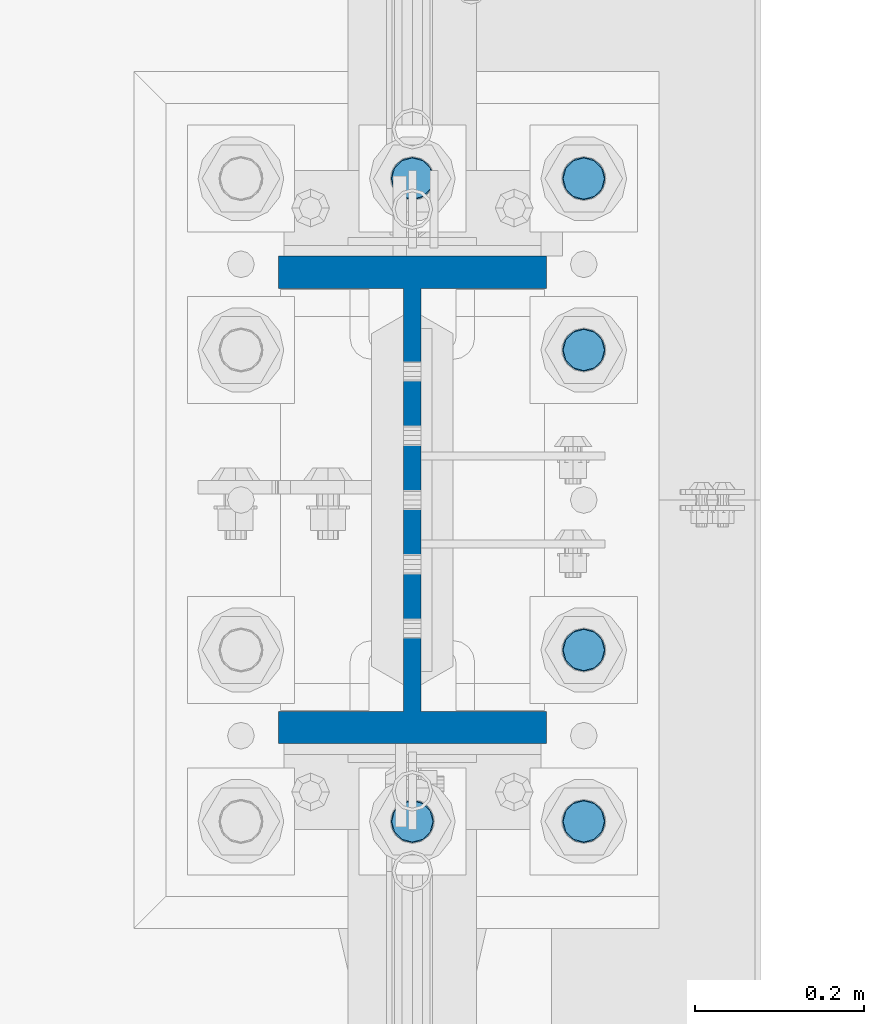
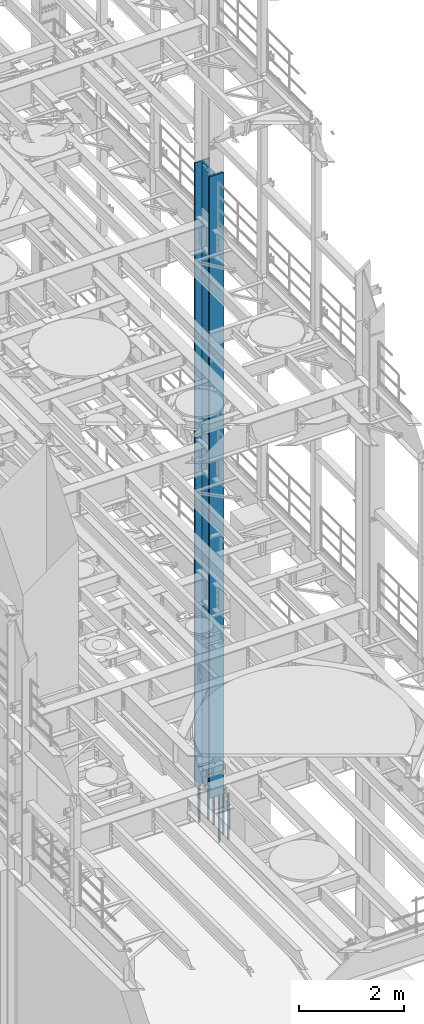
# One storey, part 758 of 1876: 7 columns, 2 elements without a shape of their own.
"""IFC2X3 building model written with IfcOpenShell, lengths in millimetres."""

from ifc_helpers import new_model, si_unit, frame, origin_with_axes, place, context, subcontext, project, spatial, faceted_brep, material, type_object, element, aggregate, save


model = new_model("IFC2X3")

# Units and contexts
model_context = context("Model", 3, precision=1e-05, world=origin_with_axes())
body_context = subcontext(model_context, "Body", "Model", "MODEL_VIEW")
ifc_project = project(units=[si_unit("LENGTHUNIT", "METRE", prefix="MILLI"), si_unit("AREAUNIT", "SQUARE_METRE"), si_unit("VOLUMEUNIT", "CUBIC_METRE"), si_unit("MASSUNIT", "GRAM", prefix="KILO"), si_unit("TIMEUNIT", "SECOND"), si_unit("PLANEANGLEUNIT", "RADIAN"), si_unit("SOLIDANGLEUNIT", "STERADIAN"), si_unit("THERMODYNAMICTEMPERATUREUNIT", "DEGREE_CELSIUS"), si_unit("LUMINOUSINTENSITYUNIT", "LUMEN")], contexts=[model_context])

# Site, building, storey
site_placement = place(None, origin_with_axes())
site = spatial("IfcSite", under=ifc_project, at=site_placement, CompositionType="ELEMENT")
building_placement = place(site_placement, origin_with_axes())
building = spatial("IfcBuilding", under=site, at=building_placement, Name="Undefined", CompositionType="ELEMENT")
storey_placement = place(building_placement, origin_with_axes())
storey = spatial("IfcBuildingStorey", under=building, at=storey_placement, Name="Undefined", CompositionType="ELEMENT", Elevation=0.0)

# Assembly, column
assembly_1_placement = place(storey_placement, origin_with_axes())
assembly_1 = element("IfcElementAssembly", 1, at=assembly_1_placement, inside=storey, Name="COLUMN", AssemblyPlace="NOTDEFINED", PredefinedType="RIGID_FRAME")
ifc_material_1 = material(Name="STEEL/A992")
column_type_1 = type_object("IfcColumnType", Name="W21X182", PredefinedType="NOTDEFINED")
column_1_placement = place(assembly_1_placement, frame((7620.0, 7620.0, 0.0), z_axis=(0.0, 1.0, 0.0), x_axis=(0.0, 0.0, 1.0)))
column_1 = element("IfcColumn", 2, at=column_1_placement, type_object=column_type_1, material=ifc_material_1, Name="COLUMN", ObjectType="W21X182", context=body_context, shape_type="Brep", body=[
    faceted_brep([(115.887500412823, 10.3187499999967, 200.025000762939), (115.887500412823, 10.3187500000004, -200.025000762939), (95.25, -10.3187500000004, -200.025000762939), (95.25, -10.3187500000004, 200.025000762939), (14528.8, -158.75, 288.925), (14528.8, 158.75, 288.925), (133.350000412822, 158.75, 288.925), (133.350000412824, -158.75, 288.925), (146.050000412824, -158.75, 250.825), (14478.0, -158.75, 250.825), (14528.8, -158.75, 250.825), (95.25, -158.75, 250.825), (146.050000412823, -10.3187500000004, 250.825), (14478.0, -10.3187500000004, 250.825), (14528.8, -10.3187500000004, 250.825), (95.25, -10.3187500000004, 250.825), (14528.8, -158.75, -288.925), (14528.8, -158.75, -250.825), (14478.0000007629, -158.75, -250.825), (146.050000412824, -158.75, -250.825), (95.25, -158.75, -250.825), (133.350000412824, -158.75, -288.925), (14528.8, 158.75, -288.925), (133.350000412822, 158.75, -288.925), (146.050000412824, 158.75, -250.825), (14478.0000007629, 158.75, -250.825), (14528.8, 158.75, -250.825), (95.25, 158.75, -250.825), (14528.8, 10.3187500000004, -250.825), (14528.8, -10.3187500000004, -250.825), (14478.0000007629, -10.3187500000004, -250.825), (146.050000412824, -10.3187500000004, -250.825), (95.25, -10.3187500000004, -250.825), (120.650000794293, -10.3187500000004, -200.025000762939), (120.650000794293, 10.3187500000004, -200.025000762939), (130.370159830384, 10.3187500000004, -201.958460608115), (130.370159830384, -10.3187500000004, -201.958460608115), (138.610512766692, 10.3187500000004, -207.464488409071), (138.610512766692, -10.3187500000004, -207.464488409071), (144.116540567648, 10.3187500000004, -215.704841345378), (144.116540567648, -10.3187500000004, -215.704841345378), (146.050000412823, 10.3187500000004, -225.42500038147), (146.050000412823, -10.3187500000004, -225.42500038147), (146.050000412824, 10.3187500000004, -250.825), (95.25, 10.3187500000004, -250.825), (14478.0000007629, 10.3187500000004, -250.825), (14481.8669204533, 10.3187500000004, -231.384681927818), (14481.8669204533, -10.3187500000004, -231.384681927818), (14492.8789760552, 10.3187500000004, -214.903976055203), (14492.8789760552, -10.3187500000004, -214.903976055203), (14509.3596819278, 10.3187500000004, -203.891920453291), (14509.3596819278, -10.3187500000004, -203.891920453291), (14528.8, -10.3187500000004, -200.025000762939), (14528.8, 10.3187500000004, -200.025000762939), (14528.8, 10.3187500000004, 200.025000762939), (14528.8, -10.3187500000004, 200.025000762939), (14509.3596811649, 10.3187500000004, 203.891920453291), (14509.3596811649, -10.3187500000004, 203.891920453291), (14492.8789752923, 10.3187500000004, 214.903976055203), (14492.8789752923, -10.3187500000004, 214.903976055203), (14481.8669196904, 10.3187500000004, 231.384681927818), (14481.8669196904, -10.3187500000004, 231.384681927818), (14478.0, 10.3187500000004, 250.825), (14528.8, 10.3187500000004, 250.825), (14528.8, 158.75, 250.825), (14478.0, 158.75, 250.825), (146.050000412824, 158.75, 250.825), (95.25, 158.75, 250.825), (95.25, 10.3187500000004, 250.825), (146.050000412824, 10.3187500000004, 250.825), (146.050000412823, 10.3187500000004, 225.42500038147), (146.050000412823, -10.3187500000004, 225.42500038147), (144.116540567648, 10.3187500000004, 215.704841345378), (144.116540567648, -10.3187500000004, 215.704841345378), (138.610512766692, 10.3187500000004, 207.464488409071), (138.610512766692, -10.3187500000004, 207.464488409071), (130.370159830384, 10.3187500000004, 201.958460608115), (130.370159830384, -10.3187500000004, 201.958460608115), (120.650000794293, 10.3187500000004, 200.025000762939), (120.650000794293, -10.3187500000004, 200.025000762939)], [[[0, 1, 2, 3]], [[4, 5, 6, 7]], [[8, 9, 10, 4, 7, 11]], [[12, 13, 14, 10, 9, 8, 11, 15]], [[16, 17, 18, 19, 20, 21]], [[22, 16, 21, 23]], [[24, 25, 26, 22, 23, 27]], [[17, 16, 22, 26, 28, 29]], [[19, 18, 17, 29, 30, 31, 32, 20]], [[33, 34, 35, 36]], [[36, 35, 37, 38]], [[38, 37, 39, 40]], [[40, 39, 41, 42]], [[42, 41, 43, 31]], [[31, 43, 44, 32]], [[27, 23, 21, 20, 32, 44]], [[43, 45, 28, 26, 25, 24, 27, 44]], [[29, 28, 45, 30]], [[30, 45, 46, 47]], [[47, 46, 48, 49]], [[49, 48, 50, 51]], [[52, 51, 50, 53]], [[54, 55, 52, 53]], [[55, 54, 56, 57]], [[57, 56, 58, 59]], [[59, 58, 60, 61]], [[61, 60, 62, 13]], [[14, 13, 62, 63]], [[64, 5, 4, 10, 14, 63]], [[5, 64, 65, 66, 67, 6]], [[11, 7, 6, 67, 68, 15]], [[66, 65, 64, 63, 62, 69, 68, 67]], [[15, 68, 69, 12]], [[12, 69, 70, 71]], [[71, 70, 72, 73]], [[73, 72, 74, 75]], [[75, 74, 76, 77]], [[77, 76, 78, 79]], [[79, 78, 0, 3]], [[33, 36, 38, 40, 42, 31, 30, 47, 49, 51, 52, 55, 57, 59, 61, 13, 12, 71, 73, 75, 77, 79, 3, 2]], [[34, 33, 2, 1]], [[78, 76, 74, 72, 70, 69, 62, 60, 58, 56, 54, 53, 50, 48, 46, 45, 43, 41, 39, 37, 35, 34, 1, 0]]]),
])
aggregate(assembly_1, [column_1])

# Assembly, columns
assembly_2_placement = place(storey_placement, origin_with_axes())
assembly_2 = element("IfcElementAssembly", 3, at=assembly_2_placement, inside=storey, Name="TEMPLATE", AssemblyPlace="NOTDEFINED", PredefinedType="RIGID_FRAME")
ifc_material_2 = material(Name="STEEL/F1554-GR.105")
column_type_2 = type_object("IfcColumnType", PredefinedType="NOTDEFINED")
column_2_placement = place(assembly_2_placement, frame((7620.0, 7239.0, 0.0), z_axis=(0.0, -1.0, 0.0), x_axis=(0.0, 0.0, -1.0)))
column_2 = element("IfcColumn", 4, at=column_2_placement, type_object=column_type_2, material=ifc_material_2, Name="ANCHOR_BOLTS", context=body_context, shape_type="Brep", body=[
    faceted_brep([(-196.85, -21.217622392719, 12.25), (-196.85, -12.25, 21.2176223927188), (-196.85, 0.0, 24.5), (-196.85, 12.25, 21.2176223927188), (-196.85, 21.217622392719, 12.25), (-196.85, 24.5, 0.0), (-196.85, 21.217622392719, -12.25), (-196.85, 12.25, -21.2176223927188), (-196.85, 0.0, -24.5), (-196.85, -12.25, -21.2176223927188), (-196.85, -21.217622392719, -12.25), (-196.85, -24.5, 0.0), (0.0, 24.5, 0.0), (0.0, 21.217622392719, -12.25), (0.0, 12.25, -21.2176223927188), (0.0, 0.0, -24.5), (0.0, -12.25, -21.2176223927188), (0.0, -21.217622392719, -12.25), (0.0, -24.5, 0.0), (0.0, -21.217622392719, 12.25), (0.0, -12.25, 21.2176223927188), (0.0, 0.0, 24.5), (0.0, 12.25, 21.2176223927188), (0.0, 21.217622392719, 12.25), (0.0, -23.4665401257871, 9.7201591820733), (0.0, -17.9605122421381, 17.9605122421383), (0.0, -9.72015918207308, 23.4665401257867), (0.0, 0.0, 25.4000000000001), (0.0, 9.72015918207308, 23.4665401257867), (0.0, 17.9605122421381, 17.9605122421383), (0.0, 23.4665401257871, 9.7201591820733), (0.0, 25.3999996185339, 9.09494701772928e-13), (0.0, 23.4665401257871, -9.7201591820733), (0.0, 17.9605122421381, -17.9605122421383), (0.0, 9.72015918207308, -23.4665401257867), (0.0, 0.0, -25.4000000000001), (0.0, -9.72015918207308, -23.4665401257867), (0.0, -17.9605122421381, -17.9605122421383), (0.0, -23.4665401257871, -9.7201591820733), (0.0, -25.3999996185375, 0.0), (673.1, -25.3999999999996, 0.0), (673.1, -23.4665401257871, 9.7201591820733), (673.1, -17.9605122421381, 17.9605122421383), (673.1, -9.72015918207308, 23.4665401257867), (673.1, 0.0, 25.4000000000001), (673.1, 9.72015918207308, 23.4665401257867), (673.1, 17.9605122421381, 17.9605122421383), (673.1, 23.4665401257871, 9.7201591820733), (673.1, 25.3999999999996, 0.0), (673.1, 23.4665401257871, -9.7201591820733), (673.1, 17.9605122421381, -17.9605122421383), (673.1, 9.72015918207308, -23.4665401257867), (673.1, 0.0, -25.4000000000001), (673.1, -9.72015918207308, -23.4665401257867), (673.1, -17.9605122421381, -17.9605122421383), (673.1, -23.4665401257871, -9.7201591820733), (673.1, -12.25, 21.2176223927188), (673.1, 0.0, 24.5), (673.1, 12.25, 21.2176223927188), (673.1, 21.217622392719, 12.25), (673.1, 24.5, 0.0), (673.1, 21.217622392719, -12.25), (673.1, 12.25, -21.2176223927188), (673.1, 0.0, -24.5), (673.1, -12.25, -21.2176223927188), (673.1, -21.217622392719, -12.25), (673.1, -24.5, 0.0), (673.1, -21.217622392719, 12.25), (869.95, -12.25, -21.2176223927188), (869.95, 0.0, -24.5), (869.95, 12.25, -21.2176223927188), (869.95, 21.217622392719, -12.25), (869.95, 24.5, 0.0), (869.95, 21.217622392719, 12.25), (869.95, 12.25, 21.2176223927188), (869.95, 0.0, 24.5), (869.95, -12.25, 21.2176223927188), (869.95, -21.217622392719, 12.25), (869.95, -24.5, 0.0), (869.95, -21.217622392719, -12.25)], [[[0, 1, 2, 3, 4, 5, 6, 7, 8, 9, 10, 11]], [[6, 5, 12, 13]], [[7, 6, 13, 14]], [[8, 7, 14, 15]], [[9, 8, 15, 16]], [[10, 9, 16, 17]], [[11, 10, 17, 18]], [[0, 11, 18, 19]], [[1, 0, 19, 20]], [[2, 1, 20, 21]], [[3, 2, 21, 22]], [[4, 3, 22, 23]], [[5, 4, 23, 12]], [[24, 25, 26, 27, 28, 29, 30, 31, 32, 33, 34, 35, 36, 37, 38, 39], [22, 21, 20, 19, 18, 17, 16, 15, 14, 13, 12, 23]], [[24, 39, 40, 41]], [[25, 24, 41, 42]], [[26, 25, 42, 43]], [[27, 26, 43, 44]], [[28, 27, 44, 45]], [[29, 28, 45, 46]], [[30, 29, 46, 47]], [[31, 30, 47, 48]], [[32, 31, 48, 49]], [[33, 32, 49, 50]], [[34, 33, 50, 51]], [[35, 34, 51, 52]], [[36, 35, 52, 53]], [[37, 36, 53, 54]], [[38, 37, 54, 55]], [[39, 38, 55, 40]], [[54, 53, 52, 51, 50, 49, 48, 47, 46, 45, 44, 43, 42, 41, 40, 55], [56, 57, 58, 59, 60, 61, 62, 63, 64, 65, 66, 67]], [[68, 69, 70, 71, 72, 73, 74, 75, 76, 77, 78, 79]], [[76, 75, 57, 56]], [[77, 76, 56, 67]], [[78, 77, 67, 66]], [[79, 78, 66, 65]], [[68, 79, 65, 64]], [[69, 68, 64, 63]], [[70, 69, 63, 62]], [[71, 70, 62, 61]], [[72, 71, 61, 60]], [[73, 72, 60, 59]], [[74, 73, 59, 58]], [[75, 74, 58, 57]]]),
])
column_3_placement = place(assembly_2_placement, frame((7823.2, 7239.0, 0.0), z_axis=(0.0, 1.0, 0.0), x_axis=(0.0, 0.0, -1.0)))
column_3 = element("IfcColumn", 5, at=column_3_placement, type_object=column_type_2, material=ifc_material_2, Name="ANCHOR_BOLTS", context=body_context, shape_type="Brep", body=[
    faceted_brep([(-196.85, -21.217622392719, 12.25), (-196.85, -12.25, 21.2176223927188), (-196.85, 0.0, 24.5), (-196.85, 12.25, 21.2176223927188), (-196.85, 21.217622392719, 12.25), (-196.85, 24.5, 0.0), (-196.85, 21.217622392719, -12.25), (-196.85, 12.25, -21.2176223927188), (-196.85, 0.0, -24.5), (-196.85, -12.25, -21.2176223927188), (-196.85, -21.217622392719, -12.25), (-196.85, -24.5, 0.0), (0.0, 24.5, 0.0), (0.0, 21.217622392719, -12.25), (0.0, 12.25, -21.2176223927188), (0.0, 0.0, -24.5), (0.0, -12.25, -21.2176223927188), (0.0, -21.217622392719, -12.25), (0.0, -24.5, 0.0), (0.0, -21.217622392719, 12.25), (0.0, -12.25, 21.2176223927188), (0.0, 0.0, 24.5), (0.0, 12.25, 21.2176223927188), (0.0, 21.217622392719, 12.25), (0.0, -23.4665401257871, 9.7201591820733), (0.0, -17.9605122421381, 17.9605122421383), (0.0, -9.72015918207308, 23.4665401257867), (0.0, 0.0, 25.4000000000001), (0.0, 9.72015918207308, 23.4665401257867), (0.0, 17.9605122421381, 17.9605122421383), (0.0, 23.4665401257871, 9.7201591820733), (0.0, 25.3999996185339, 9.09494701772928e-13), (0.0, 23.4665401257871, -9.7201591820733), (0.0, 17.9605122421381, -17.9605122421383), (0.0, 9.72015918207308, -23.4665401257867), (0.0, 0.0, -25.4000000000001), (0.0, -9.72015918207308, -23.4665401257867), (0.0, -17.9605122421381, -17.9605122421383), (0.0, -23.4665401257871, -9.7201591820733), (0.0, -25.3999996185375, 0.0), (673.1, -25.3999999999996, 0.0), (673.1, -23.4665401257871, 9.7201591820733), (673.1, -17.9605122421381, 17.9605122421383), (673.1, -9.72015918207308, 23.4665401257867), (673.1, 0.0, 25.4000000000001), (673.1, 9.72015918207308, 23.4665401257867), (673.1, 17.9605122421381, 17.9605122421383), (673.1, 23.4665401257871, 9.7201591820733), (673.1, 25.3999999999996, 0.0), (673.1, 23.4665401257871, -9.7201591820733), (673.1, 17.9605122421381, -17.9605122421383), (673.1, 9.72015918207308, -23.4665401257867), (673.1, 0.0, -25.4000000000001), (673.1, -9.72015918207308, -23.4665401257867), (673.1, -17.9605122421381, -17.9605122421383), (673.1, -23.4665401257871, -9.7201591820733), (673.1, -12.25, 21.2176223927188), (673.1, 0.0, 24.5), (673.1, 12.25, 21.2176223927188), (673.1, 21.217622392719, 12.25), (673.1, 24.5, 0.0), (673.1, 21.217622392719, -12.25), (673.1, 12.25, -21.2176223927188), (673.1, 0.0, -24.5), (673.1, -12.25, -21.2176223927188), (673.1, -21.217622392719, -12.25), (673.1, -24.5, 0.0), (673.1, -21.217622392719, 12.25), (869.95, -12.25, -21.2176223927188), (869.95, 0.0, -24.5), (869.95, 12.25, -21.2176223927188), (869.95, 21.217622392719, -12.25), (869.95, 24.5, 0.0), (869.95, 21.217622392719, 12.25), (869.95, 12.25, 21.2176223927188), (869.95, 0.0, 24.5), (869.95, -12.25, 21.2176223927188), (869.95, -21.217622392719, 12.25), (869.95, -24.5, 0.0), (869.95, -21.217622392719, -12.25)], [[[0, 1, 2, 3, 4, 5, 6, 7, 8, 9, 10, 11]], [[6, 5, 12, 13]], [[7, 6, 13, 14]], [[8, 7, 14, 15]], [[9, 8, 15, 16]], [[10, 9, 16, 17]], [[11, 10, 17, 18]], [[0, 11, 18, 19]], [[1, 0, 19, 20]], [[2, 1, 20, 21]], [[3, 2, 21, 22]], [[4, 3, 22, 23]], [[5, 4, 23, 12]], [[24, 25, 26, 27, 28, 29, 30, 31, 32, 33, 34, 35, 36, 37, 38, 39], [22, 21, 20, 19, 18, 17, 16, 15, 14, 13, 12, 23]], [[24, 39, 40, 41]], [[25, 24, 41, 42]], [[26, 25, 42, 43]], [[27, 26, 43, 44]], [[28, 27, 44, 45]], [[29, 28, 45, 46]], [[30, 29, 46, 47]], [[31, 30, 47, 48]], [[32, 31, 48, 49]], [[33, 32, 49, 50]], [[34, 33, 50, 51]], [[35, 34, 51, 52]], [[36, 35, 52, 53]], [[37, 36, 53, 54]], [[38, 37, 54, 55]], [[39, 38, 55, 40]], [[54, 53, 52, 51, 50, 49, 48, 47, 46, 45, 44, 43, 42, 41, 40, 55], [56, 57, 58, 59, 60, 61, 62, 63, 64, 65, 66, 67]], [[68, 69, 70, 71, 72, 73, 74, 75, 76, 77, 78, 79]], [[76, 75, 57, 56]], [[77, 76, 56, 67]], [[78, 77, 67, 66]], [[79, 78, 66, 65]], [[68, 79, 65, 64]], [[69, 68, 64, 63]], [[70, 69, 63, 62]], [[71, 70, 62, 61]], [[72, 71, 61, 60]], [[73, 72, 60, 59]], [[74, 73, 59, 58]], [[75, 74, 58, 57]]]),
])
column_4_placement = place(assembly_2_placement, frame((7823.2, 7442.2, 0.0), z_axis=(0.0, 1.0, 0.0), x_axis=(0.0, 0.0, -1.0)))
column_4 = element("IfcColumn", 6, at=column_4_placement, type_object=column_type_2, material=ifc_material_2, Name="ANCHOR_BOLTS", context=body_context, shape_type="Brep", body=[
    faceted_brep([(-196.85, -21.217622392719, 12.25), (-196.85, -12.25, 21.2176223927188), (-196.85, 0.0, 24.5), (-196.85, 12.25, 21.2176223927188), (-196.85, 21.217622392719, 12.25), (-196.85, 24.5, 0.0), (-196.85, 21.217622392719, -12.25), (-196.85, 12.25, -21.2176223927188), (-196.85, 0.0, -24.5), (-196.85, -12.25, -21.2176223927188), (-196.85, -21.217622392719, -12.25), (-196.85, -24.5, 0.0), (0.0, 24.5, 0.0), (0.0, 21.217622392719, -12.25), (0.0, 12.25, -21.2176223927188), (0.0, 0.0, -24.5), (0.0, -12.25, -21.2176223927188), (0.0, -21.217622392719, -12.25), (0.0, -24.5, 0.0), (0.0, -21.217622392719, 12.25), (0.0, -12.25, 21.2176223927188), (0.0, 0.0, 24.5), (0.0, 12.25, 21.2176223927188), (0.0, 21.217622392719, 12.25), (0.0, -23.4665401257871, 9.7201591820733), (0.0, -17.9605122421381, 17.9605122421383), (0.0, -9.72015918207308, 23.4665401257867), (0.0, 0.0, 25.4000000000001), (0.0, 9.72015918207308, 23.4665401257867), (0.0, 17.9605122421381, 17.9605122421383), (0.0, 23.4665401257871, 9.7201591820733), (0.0, 25.3999996185339, 9.09494701772928e-13), (0.0, 23.4665401257871, -9.7201591820733), (0.0, 17.9605122421381, -17.9605122421383), (0.0, 9.72015918207308, -23.4665401257867), (0.0, 0.0, -25.4000000000001), (0.0, -9.72015918207308, -23.4665401257867), (0.0, -17.9605122421381, -17.9605122421383), (0.0, -23.4665401257871, -9.7201591820733), (0.0, -25.3999996185375, 0.0), (673.1, -25.3999999999996, 0.0), (673.1, -23.4665401257871, 9.7201591820733), (673.1, -17.9605122421381, 17.9605122421383), (673.1, -9.72015918207308, 23.4665401257867), (673.1, 0.0, 25.4000000000001), (673.1, 9.72015918207308, 23.4665401257867), (673.1, 17.9605122421381, 17.9605122421383), (673.1, 23.4665401257871, 9.7201591820733), (673.1, 25.3999999999996, 0.0), (673.1, 23.4665401257871, -9.7201591820733), (673.1, 17.9605122421381, -17.9605122421383), (673.1, 9.72015918207308, -23.4665401257867), (673.1, 0.0, -25.4000000000001), (673.1, -9.72015918207308, -23.4665401257867), (673.1, -17.9605122421381, -17.9605122421383), (673.1, -23.4665401257871, -9.7201591820733), (673.1, -12.25, 21.2176223927188), (673.1, 0.0, 24.5), (673.1, 12.25, 21.2176223927188), (673.1, 21.217622392719, 12.25), (673.1, 24.5, 0.0), (673.1, 21.217622392719, -12.25), (673.1, 12.25, -21.2176223927188), (673.1, 0.0, -24.5), (673.1, -12.25, -21.2176223927188), (673.1, -21.217622392719, -12.25), (673.1, -24.5, 0.0), (673.1, -21.217622392719, 12.25), (869.95, -12.25, -21.2176223927188), (869.95, 0.0, -24.5), (869.95, 12.25, -21.2176223927188), (869.95, 21.217622392719, -12.25), (869.95, 24.5, 0.0), (869.95, 21.217622392719, 12.25), (869.95, 12.25, 21.2176223927188), (869.95, 0.0, 24.5), (869.95, -12.25, 21.2176223927188), (869.95, -21.217622392719, 12.25), (869.95, -24.5, 0.0), (869.95, -21.217622392719, -12.25)], [[[0, 1, 2, 3, 4, 5, 6, 7, 8, 9, 10, 11]], [[6, 5, 12, 13]], [[7, 6, 13, 14]], [[8, 7, 14, 15]], [[9, 8, 15, 16]], [[10, 9, 16, 17]], [[11, 10, 17, 18]], [[0, 11, 18, 19]], [[1, 0, 19, 20]], [[2, 1, 20, 21]], [[3, 2, 21, 22]], [[4, 3, 22, 23]], [[5, 4, 23, 12]], [[24, 25, 26, 27, 28, 29, 30, 31, 32, 33, 34, 35, 36, 37, 38, 39], [22, 21, 20, 19, 18, 17, 16, 15, 14, 13, 12, 23]], [[24, 39, 40, 41]], [[25, 24, 41, 42]], [[26, 25, 42, 43]], [[27, 26, 43, 44]], [[28, 27, 44, 45]], [[29, 28, 45, 46]], [[30, 29, 46, 47]], [[31, 30, 47, 48]], [[32, 31, 48, 49]], [[33, 32, 49, 50]], [[34, 33, 50, 51]], [[35, 34, 51, 52]], [[36, 35, 52, 53]], [[37, 36, 53, 54]], [[38, 37, 54, 55]], [[39, 38, 55, 40]], [[54, 53, 52, 51, 50, 49, 48, 47, 46, 45, 44, 43, 42, 41, 40, 55], [56, 57, 58, 59, 60, 61, 62, 63, 64, 65, 66, 67]], [[68, 69, 70, 71, 72, 73, 74, 75, 76, 77, 78, 79]], [[76, 75, 57, 56]], [[77, 76, 56, 67]], [[78, 77, 67, 66]], [[79, 78, 66, 65]], [[68, 79, 65, 64]], [[69, 68, 64, 63]], [[70, 69, 63, 62]], [[71, 70, 62, 61]], [[72, 71, 61, 60]], [[73, 72, 60, 59]], [[74, 73, 59, 58]], [[75, 74, 58, 57]]]),
])
column_5_placement = place(assembly_2_placement, frame((7823.2, 7797.8, 0.0), z_axis=(0.0, 1.0, 0.0), x_axis=(0.0, 0.0, -1.0)))
column_5 = element("IfcColumn", 7, at=column_5_placement, type_object=column_type_2, material=ifc_material_2, Name="ANCHOR_BOLTS", context=body_context, shape_type="Brep", body=[
    faceted_brep([(-196.85, -21.217622392719, 12.25), (-196.85, -12.25, 21.2176223927188), (-196.85, 0.0, 24.5), (-196.85, 12.25, 21.2176223927188), (-196.85, 21.217622392719, 12.25), (-196.85, 24.5, 0.0), (-196.85, 21.217622392719, -12.25), (-196.85, 12.25, -21.2176223927188), (-196.85, 0.0, -24.5), (-196.85, -12.25, -21.2176223927188), (-196.85, -21.217622392719, -12.25), (-196.85, -24.5, 0.0), (0.0, 24.5, 0.0), (0.0, 21.217622392719, -12.25), (0.0, 12.25, -21.2176223927188), (0.0, 0.0, -24.5), (0.0, -12.25, -21.2176223927188), (0.0, -21.217622392719, -12.25), (0.0, -24.5, 0.0), (0.0, -21.217622392719, 12.25), (0.0, -12.25, 21.2176223927188), (0.0, 0.0, 24.5), (0.0, 12.25, 21.2176223927188), (0.0, 21.217622392719, 12.25), (0.0, -23.4665401257871, 9.7201591820733), (0.0, -17.9605122421381, 17.9605122421383), (0.0, -9.72015918207308, 23.4665401257867), (0.0, 0.0, 25.4000000000001), (0.0, 9.72015918207308, 23.4665401257867), (0.0, 17.9605122421381, 17.9605122421383), (0.0, 23.4665401257871, 9.7201591820733), (0.0, 25.3999996185339, 9.09494701772928e-13), (0.0, 23.4665401257871, -9.7201591820733), (0.0, 17.9605122421381, -17.9605122421383), (0.0, 9.72015918207308, -23.4665401257867), (0.0, 0.0, -25.4000000000001), (0.0, -9.72015918207308, -23.4665401257867), (0.0, -17.9605122421381, -17.9605122421383), (0.0, -23.4665401257871, -9.7201591820733), (0.0, -25.3999996185375, 0.0), (673.1, -25.3999999999996, 0.0), (673.1, -23.4665401257871, 9.7201591820733), (673.1, -17.9605122421381, 17.9605122421383), (673.1, -9.72015918207308, 23.4665401257867), (673.1, 0.0, 25.4000000000001), (673.1, 9.72015918207308, 23.4665401257867), (673.1, 17.9605122421381, 17.9605122421383), (673.1, 23.4665401257871, 9.7201591820733), (673.1, 25.3999999999996, 0.0), (673.1, 23.4665401257871, -9.7201591820733), (673.1, 17.9605122421381, -17.9605122421383), (673.1, 9.72015918207308, -23.4665401257867), (673.1, 0.0, -25.4000000000001), (673.1, -9.72015918207308, -23.4665401257867), (673.1, -17.9605122421381, -17.9605122421383), (673.1, -23.4665401257871, -9.7201591820733), (673.1, -12.25, 21.2176223927188), (673.1, 0.0, 24.5), (673.1, 12.25, 21.2176223927188), (673.1, 21.217622392719, 12.25), (673.1, 24.5, 0.0), (673.1, 21.217622392719, -12.25), (673.1, 12.25, -21.2176223927188), (673.1, 0.0, -24.5), (673.1, -12.25, -21.2176223927188), (673.1, -21.217622392719, -12.25), (673.1, -24.5, 0.0), (673.1, -21.217622392719, 12.25), (869.95, -12.25, -21.2176223927188), (869.95, 0.0, -24.5), (869.95, 12.25, -21.2176223927188), (869.95, 21.217622392719, -12.25), (869.95, 24.5, 0.0), (869.95, 21.217622392719, 12.25), (869.95, 12.25, 21.2176223927188), (869.95, 0.0, 24.5), (869.95, -12.25, 21.2176223927188), (869.95, -21.217622392719, 12.25), (869.95, -24.5, 0.0), (869.95, -21.217622392719, -12.25)], [[[0, 1, 2, 3, 4, 5, 6, 7, 8, 9, 10, 11]], [[6, 5, 12, 13]], [[7, 6, 13, 14]], [[8, 7, 14, 15]], [[9, 8, 15, 16]], [[10, 9, 16, 17]], [[11, 10, 17, 18]], [[0, 11, 18, 19]], [[1, 0, 19, 20]], [[2, 1, 20, 21]], [[3, 2, 21, 22]], [[4, 3, 22, 23]], [[5, 4, 23, 12]], [[24, 25, 26, 27, 28, 29, 30, 31, 32, 33, 34, 35, 36, 37, 38, 39], [22, 21, 20, 19, 18, 17, 16, 15, 14, 13, 12, 23]], [[24, 39, 40, 41]], [[25, 24, 41, 42]], [[26, 25, 42, 43]], [[27, 26, 43, 44]], [[28, 27, 44, 45]], [[29, 28, 45, 46]], [[30, 29, 46, 47]], [[31, 30, 47, 48]], [[32, 31, 48, 49]], [[33, 32, 49, 50]], [[34, 33, 50, 51]], [[35, 34, 51, 52]], [[36, 35, 52, 53]], [[37, 36, 53, 54]], [[38, 37, 54, 55]], [[39, 38, 55, 40]], [[54, 53, 52, 51, 50, 49, 48, 47, 46, 45, 44, 43, 42, 41, 40, 55], [56, 57, 58, 59, 60, 61, 62, 63, 64, 65, 66, 67]], [[68, 69, 70, 71, 72, 73, 74, 75, 76, 77, 78, 79]], [[76, 75, 57, 56]], [[77, 76, 56, 67]], [[78, 77, 67, 66]], [[79, 78, 66, 65]], [[68, 79, 65, 64]], [[69, 68, 64, 63]], [[70, 69, 63, 62]], [[71, 70, 62, 61]], [[72, 71, 61, 60]], [[73, 72, 60, 59]], [[74, 73, 59, 58]], [[75, 74, 58, 57]]]),
])
column_6_placement = place(assembly_2_placement, frame((7620.0, 8001.0, 0.0), z_axis=(0.0, -1.0, 0.0), x_axis=(0.0, 0.0, -1.0)))
column_6 = element("IfcColumn", 8, at=column_6_placement, type_object=column_type_2, material=ifc_material_2, Name="ANCHOR_BOLTS", context=body_context, shape_type="Brep", body=[
    faceted_brep([(-196.85, -21.217622392719, 12.25), (-196.85, -12.25, 21.2176223927188), (-196.85, 0.0, 24.5), (-196.85, 12.25, 21.2176223927188), (-196.85, 21.217622392719, 12.25), (-196.85, 24.5, 0.0), (-196.85, 21.217622392719, -12.25), (-196.85, 12.25, -21.2176223927188), (-196.85, 0.0, -24.5), (-196.85, -12.25, -21.2176223927188), (-196.85, -21.217622392719, -12.25), (-196.85, -24.5, 0.0), (0.0, 24.5, 0.0), (0.0, 21.217622392719, -12.25), (0.0, 12.25, -21.2176223927188), (0.0, 0.0, -24.5), (0.0, -12.25, -21.2176223927188), (0.0, -21.217622392719, -12.25), (0.0, -24.5, 0.0), (0.0, -21.217622392719, 12.25), (0.0, -12.25, 21.2176223927188), (0.0, 0.0, 24.5), (0.0, 12.25, 21.2176223927188), (0.0, 21.217622392719, 12.25), (0.0, -23.4665401257871, 9.7201591820733), (0.0, -17.9605122421381, 17.9605122421383), (0.0, -9.72015918207308, 23.4665401257867), (0.0, 0.0, 25.4000000000001), (0.0, 9.72015918207308, 23.4665401257867), (0.0, 17.9605122421381, 17.9605122421383), (0.0, 23.4665401257871, 9.7201591820733), (0.0, 25.3999996185339, 9.09494701772928e-13), (0.0, 23.4665401257871, -9.7201591820733), (0.0, 17.9605122421381, -17.9605122421383), (0.0, 9.72015918207308, -23.4665401257867), (0.0, 0.0, -25.4000000000001), (0.0, -9.72015918207308, -23.4665401257867), (0.0, -17.9605122421381, -17.9605122421383), (0.0, -23.4665401257871, -9.7201591820733), (0.0, -25.3999996185375, 0.0), (673.1, -25.3999999999996, 0.0), (673.1, -23.4665401257871, 9.7201591820733), (673.1, -17.9605122421381, 17.9605122421383), (673.1, -9.72015918207308, 23.4665401257867), (673.1, 0.0, 25.4000000000001), (673.1, 9.72015918207308, 23.4665401257867), (673.1, 17.9605122421381, 17.9605122421383), (673.1, 23.4665401257871, 9.7201591820733), (673.1, 25.3999999999996, 0.0), (673.1, 23.4665401257871, -9.7201591820733), (673.1, 17.9605122421381, -17.9605122421383), (673.1, 9.72015918207308, -23.4665401257867), (673.1, 0.0, -25.4000000000001), (673.1, -9.72015918207308, -23.4665401257867), (673.1, -17.9605122421381, -17.9605122421383), (673.1, -23.4665401257871, -9.7201591820733), (673.1, -12.25, 21.2176223927188), (673.1, 0.0, 24.5), (673.1, 12.25, 21.2176223927188), (673.1, 21.217622392719, 12.25), (673.1, 24.5, 0.0), (673.1, 21.217622392719, -12.25), (673.1, 12.25, -21.2176223927188), (673.1, 0.0, -24.5), (673.1, -12.25, -21.2176223927188), (673.1, -21.217622392719, -12.25), (673.1, -24.5, 0.0), (673.1, -21.217622392719, 12.25), (869.95, -12.25, -21.2176223927188), (869.95, 0.0, -24.5), (869.95, 12.25, -21.2176223927188), (869.95, 21.217622392719, -12.25), (869.95, 24.5, 0.0), (869.95, 21.217622392719, 12.25), (869.95, 12.25, 21.2176223927188), (869.95, 0.0, 24.5), (869.95, -12.25, 21.2176223927188), (869.95, -21.217622392719, 12.25), (869.95, -24.5, 0.0), (869.95, -21.217622392719, -12.25)], [[[0, 1, 2, 3, 4, 5, 6, 7, 8, 9, 10, 11]], [[6, 5, 12, 13]], [[7, 6, 13, 14]], [[8, 7, 14, 15]], [[9, 8, 15, 16]], [[10, 9, 16, 17]], [[11, 10, 17, 18]], [[0, 11, 18, 19]], [[1, 0, 19, 20]], [[2, 1, 20, 21]], [[3, 2, 21, 22]], [[4, 3, 22, 23]], [[5, 4, 23, 12]], [[24, 25, 26, 27, 28, 29, 30, 31, 32, 33, 34, 35, 36, 37, 38, 39], [22, 21, 20, 19, 18, 17, 16, 15, 14, 13, 12, 23]], [[24, 39, 40, 41]], [[25, 24, 41, 42]], [[26, 25, 42, 43]], [[27, 26, 43, 44]], [[28, 27, 44, 45]], [[29, 28, 45, 46]], [[30, 29, 46, 47]], [[31, 30, 47, 48]], [[32, 31, 48, 49]], [[33, 32, 49, 50]], [[34, 33, 50, 51]], [[35, 34, 51, 52]], [[36, 35, 52, 53]], [[37, 36, 53, 54]], [[38, 37, 54, 55]], [[39, 38, 55, 40]], [[54, 53, 52, 51, 50, 49, 48, 47, 46, 45, 44, 43, 42, 41, 40, 55], [56, 57, 58, 59, 60, 61, 62, 63, 64, 65, 66, 67]], [[68, 69, 70, 71, 72, 73, 74, 75, 76, 77, 78, 79]], [[76, 75, 57, 56]], [[77, 76, 56, 67]], [[78, 77, 67, 66]], [[79, 78, 66, 65]], [[68, 79, 65, 64]], [[69, 68, 64, 63]], [[70, 69, 63, 62]], [[71, 70, 62, 61]], [[72, 71, 61, 60]], [[73, 72, 60, 59]], [[74, 73, 59, 58]], [[75, 74, 58, 57]]]),
])
column_7_placement = place(assembly_2_placement, frame((7823.2, 8001.0, 0.0), z_axis=(0.0, 1.0, 0.0), x_axis=(0.0, 0.0, -1.0)))
column_7 = element("IfcColumn", 9, at=column_7_placement, type_object=column_type_2, material=ifc_material_2, Name="ANCHOR_BOLTS", context=body_context, shape_type="Brep", body=[
    faceted_brep([(-196.85, -21.217622392719, 12.25), (-196.85, -12.25, 21.2176223927188), (-196.85, 0.0, 24.5), (-196.85, 12.25, 21.2176223927188), (-196.85, 21.217622392719, 12.25), (-196.85, 24.5, 0.0), (-196.85, 21.217622392719, -12.25), (-196.85, 12.25, -21.2176223927188), (-196.85, 0.0, -24.5), (-196.85, -12.25, -21.2176223927188), (-196.85, -21.217622392719, -12.25), (-196.85, -24.5, 0.0), (0.0, 24.5, 0.0), (0.0, 21.217622392719, -12.25), (0.0, 12.25, -21.2176223927188), (0.0, 0.0, -24.5), (0.0, -12.25, -21.2176223927188), (0.0, -21.217622392719, -12.25), (0.0, -24.5, 0.0), (0.0, -21.217622392719, 12.25), (0.0, -12.25, 21.2176223927188), (0.0, 0.0, 24.5), (0.0, 12.25, 21.2176223927188), (0.0, 21.217622392719, 12.25), (0.0, -23.4665401257871, 9.7201591820733), (0.0, -17.9605122421381, 17.9605122421383), (0.0, -9.72015918207308, 23.4665401257867), (0.0, 0.0, 25.4000000000001), (0.0, 9.72015918207308, 23.4665401257867), (0.0, 17.9605122421381, 17.9605122421383), (0.0, 23.4665401257871, 9.7201591820733), (0.0, 25.3999996185339, 9.09494701772928e-13), (0.0, 23.4665401257871, -9.7201591820733), (0.0, 17.9605122421381, -17.9605122421383), (0.0, 9.72015918207308, -23.4665401257867), (0.0, 0.0, -25.4000000000001), (0.0, -9.72015918207308, -23.4665401257867), (0.0, -17.9605122421381, -17.9605122421383), (0.0, -23.4665401257871, -9.7201591820733), (0.0, -25.3999996185375, 0.0), (673.1, -25.3999999999996, 0.0), (673.1, -23.4665401257871, 9.7201591820733), (673.1, -17.9605122421381, 17.9605122421383), (673.1, -9.72015918207308, 23.4665401257867), (673.1, 0.0, 25.4000000000001), (673.1, 9.72015918207308, 23.4665401257867), (673.1, 17.9605122421381, 17.9605122421383), (673.1, 23.4665401257871, 9.7201591820733), (673.1, 25.3999999999996, 0.0), (673.1, 23.4665401257871, -9.7201591820733), (673.1, 17.9605122421381, -17.9605122421383), (673.1, 9.72015918207308, -23.4665401257867), (673.1, 0.0, -25.4000000000001), (673.1, -9.72015918207308, -23.4665401257867), (673.1, -17.9605122421381, -17.9605122421383), (673.1, -23.4665401257871, -9.7201591820733), (673.1, -12.25, 21.2176223927188), (673.1, 0.0, 24.5), (673.1, 12.25, 21.2176223927188), (673.1, 21.217622392719, 12.25), (673.1, 24.5, 0.0), (673.1, 21.217622392719, -12.25), (673.1, 12.25, -21.2176223927188), (673.1, 0.0, -24.5), (673.1, -12.25, -21.2176223927188), (673.1, -21.217622392719, -12.25), (673.1, -24.5, 0.0), (673.1, -21.217622392719, 12.25), (869.95, -12.25, -21.2176223927188), (869.95, 0.0, -24.5), (869.95, 12.25, -21.2176223927188), (869.95, 21.217622392719, -12.25), (869.95, 24.5, 0.0), (869.95, 21.217622392719, 12.25), (869.95, 12.25, 21.2176223927188), (869.95, 0.0, 24.5), (869.95, -12.25, 21.2176223927188), (869.95, -21.217622392719, 12.25), (869.95, -24.5, 0.0), (869.95, -21.217622392719, -12.25)], [[[0, 1, 2, 3, 4, 5, 6, 7, 8, 9, 10, 11]], [[6, 5, 12, 13]], [[7, 6, 13, 14]], [[8, 7, 14, 15]], [[9, 8, 15, 16]], [[10, 9, 16, 17]], [[11, 10, 17, 18]], [[0, 11, 18, 19]], [[1, 0, 19, 20]], [[2, 1, 20, 21]], [[3, 2, 21, 22]], [[4, 3, 22, 23]], [[5, 4, 23, 12]], [[24, 25, 26, 27, 28, 29, 30, 31, 32, 33, 34, 35, 36, 37, 38, 39], [22, 21, 20, 19, 18, 17, 16, 15, 14, 13, 12, 23]], [[24, 39, 40, 41]], [[25, 24, 41, 42]], [[26, 25, 42, 43]], [[27, 26, 43, 44]], [[28, 27, 44, 45]], [[29, 28, 45, 46]], [[30, 29, 46, 47]], [[31, 30, 47, 48]], [[32, 31, 48, 49]], [[33, 32, 49, 50]], [[34, 33, 50, 51]], [[35, 34, 51, 52]], [[36, 35, 52, 53]], [[37, 36, 53, 54]], [[38, 37, 54, 55]], [[39, 38, 55, 40]], [[54, 53, 52, 51, 50, 49, 48, 47, 46, 45, 44, 43, 42, 41, 40, 55], [56, 57, 58, 59, 60, 61, 62, 63, 64, 65, 66, 67]], [[68, 69, 70, 71, 72, 73, 74, 75, 76, 77, 78, 79]], [[76, 75, 57, 56]], [[77, 76, 56, 67]], [[78, 77, 67, 66]], [[79, 78, 66, 65]], [[68, 79, 65, 64]], [[69, 68, 64, 63]], [[70, 69, 63, 62]], [[71, 70, 62, 61]], [[72, 71, 61, 60]], [[73, 72, 60, 59]], [[74, 73, 59, 58]], [[75, 74, 58, 57]]]),
])
aggregate(assembly_2, [column_2, column_3, column_4, column_5, column_6, column_7])

save(model, "model.ifc")
